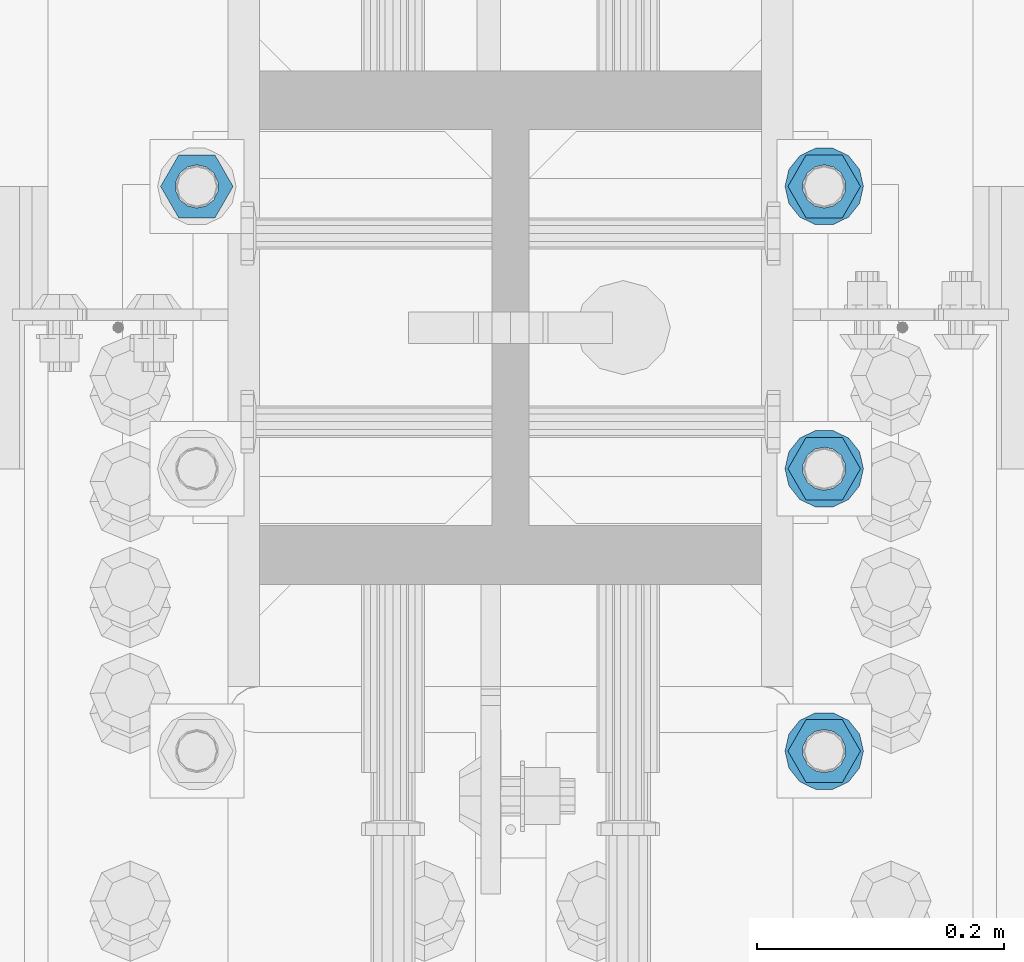
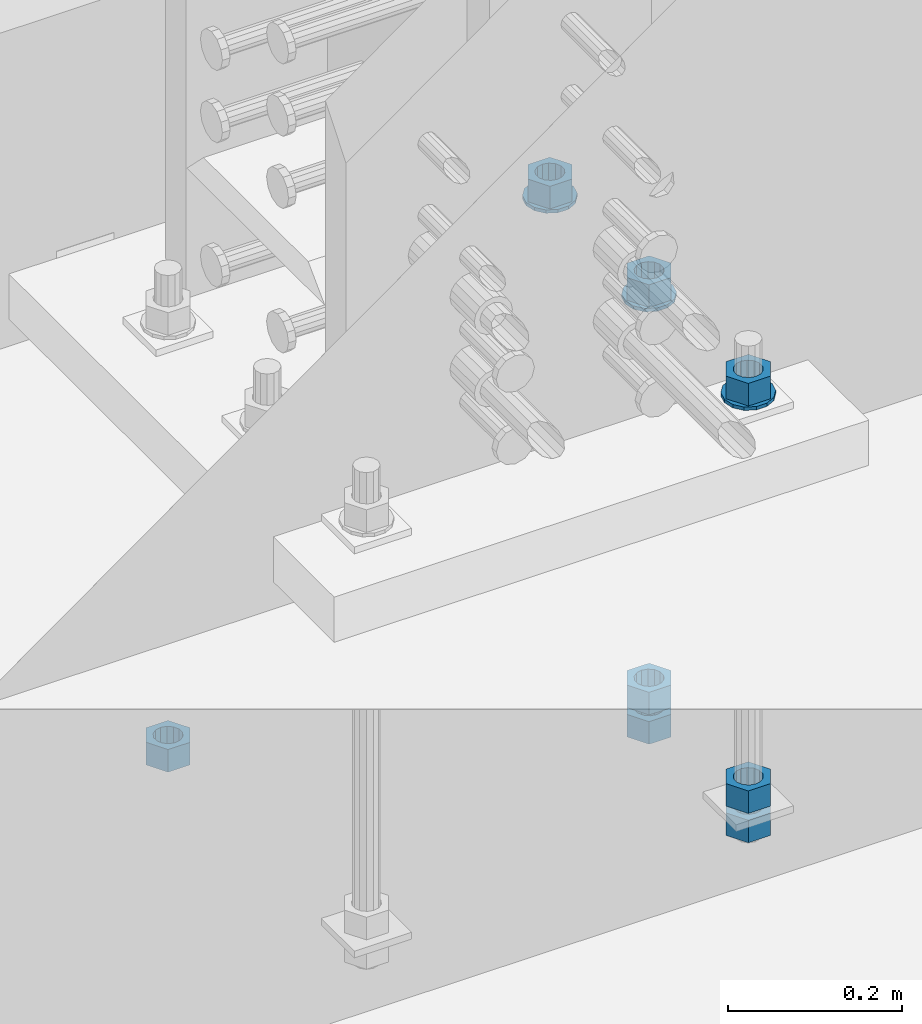
# One storey, part 1014 of 1763: 11 columns, 1 element without a shape of its own.
"""IFC2X3 building model written with IfcOpenShell, lengths in millimetres."""

import ifcopenshell
import ifcopenshell.guid

model = None  # the IFC model being written
_history = None  # IfcOwnerHistory: only IFC2X3 demands one
_inside = {}  # id of a spatial element -> (the spatial element, [elements in it])
_under = {}  # id of a project, library or spatial element -> (it, [spatial elements below it])
_declared = {}  # id of a project -> (the project, [libraries it declares])
_typed = {}  # id of a type object -> (the type object, [elements of that type])
_made_of = {}  # id of a material, layer set ... -> (it, [elements and type objects made of it])


def new_model(schema):
    """Start an empty IFC model of exactly this schema.

    Asked for "IFC4X3", IfcOpenShell would pick the latest addendum, in which some entities
    have other attributes; the version numbers below select the first issue.
    IFC2X3 requires an IfcOwnerHistory on every rooted entity: one is made here for all.
    """
    global model, _history
    if schema == "IFC4X3":
        model = ifcopenshell.file(schema_version=(4, 3, 0, 0))
    else:
        model = ifcopenshell.file(schema=schema)
    _inside.clear()
    _under.clear()
    _declared.clear()
    _typed.clear()
    _made_of.clear()
    _history = None
    if model.schema == "IFC2X3":
        org = make("IfcOrganization", Name="unknown")
        user = make(
            "IfcPersonAndOrganization",
            ThePerson=make("IfcPerson", FamilyName="unknown"),
            TheOrganization=org,
        )
        app = make(
            "IfcApplication",
            ApplicationDeveloper=org,
            Version="unknown",
            ApplicationFullName="unknown",
            ApplicationIdentifier="unknown",
        )
        _history = make(
            "IfcOwnerHistory",
            OwningUser=user,
            OwningApplication=app,
            ChangeAction="ADDED",
            CreationDate=0,
        )
    return model


def make(cls, **values):
    """One entity of the class cls with the attributes given. An attribute that is None is left unset."""
    return model.create_entity(
        cls, **{name: value for name, value in values.items() if value is not None}
    )


def rooted(cls, **values):
    """An entity with a GlobalId (a new one), such as an element, a storey or a relation."""
    return make(cls, GlobalId=ifcopenshell.guid.new(), OwnerHistory=_history, **values)


def si_unit(unit_type, name, prefix=None):
    """IfcSIUnit, for example si_unit("LENGTHUNIT", "METRE", prefix="MILLI")."""
    return make("IfcSIUnit", UnitType=unit_type, Prefix=prefix, Name=name)


def assignment(units):
    """IfcUnitAssignment: the units of a project."""
    return None if units is None else make("IfcUnitAssignment", Units=units)


def point(xyz):
    """IfcCartesianPoint."""
    return None if xyz is None else make("IfcCartesianPoint", Coordinates=xyz)


def direction(xyz):
    """IfcDirection."""
    return None if xyz is None else make("IfcDirection", DirectionRatios=xyz)


def frame(location, z_axis=None, x_axis=None):
    """IfcAxis2Placement3D, a coordinate frame: its origin and axes. An axis left out is left unset."""
    return make(
        "IfcAxis2Placement3D",
        Location=point(location),
        Axis=direction(z_axis),
        RefDirection=direction(x_axis),
    )


def origin_with_axes():
    """The frame at (0, 0, 0) with the z axis (0, 0, 1) and the x axis (1, 0, 0) written out."""
    return frame((0.0, 0.0, 0.0), z_axis=(0.0, 0.0, 1.0), x_axis=(1.0, 0.0, 0.0))


def place(relative_to, where):
    """IfcLocalPlacement: puts the frame where relative to a parent placement (None: the world)."""
    return make(
        "IfcLocalPlacement", PlacementRelTo=relative_to, RelativePlacement=where
    )


def context(
    kind, dimensions, precision=None, world=None, true_north=None, identifier=None
):
    """IfcGeometricRepresentationContext, for example the 3D "Model" context."""
    return make(
        "IfcGeometricRepresentationContext",
        ContextIdentifier=identifier,
        ContextType=kind,
        CoordinateSpaceDimension=dimensions,
        Precision=precision,
        WorldCoordinateSystem=world,
        TrueNorth=true_north,
    )


def subcontext(parent, identifier, kind, view, scale=None):
    """IfcGeometricRepresentationSubContext, for example "Body" below "Model"."""
    return make(
        "IfcGeometricRepresentationSubContext",
        ContextIdentifier=identifier,
        ContextType=kind,
        ParentContext=parent,
        TargetScale=scale,
        TargetView=view,
    )


def project(units=None, contexts=None):
    """IfcProject with its units and contexts."""
    return rooted(
        "IfcProject",
        Name="project",
        RepresentationContexts=contexts,
        UnitsInContext=assignment(units),
    )


def spatial(cls, under=None, at=None, **own):
    """A site, building, storey or space (cls), placed at a placement, below another one or the project."""
    s = rooted(cls, ObjectPlacement=at, **own)
    if under is not None:
        _under.setdefault(under.id(), (under, []))[1].append(s)
    return s


def faces_of(points, faces, orient=None, outer=None):
    """IfcFace entities. A face is a list of loops; a loop is a list of indices into points, from 0.

    orient and outer hold one flag for each loop. By default every Orientation is true, the
    first loop of a face is its IfcFaceOuterBound and the others are IfcFaceBound.
    """
    made = []
    for i, loops in enumerate(faces):
        bounds = []
        for j, loop in enumerate(loops):
            is_outer = j == 0 if outer is None else outer[i][j]
            bounds.append(
                make(
                    "IfcFaceOuterBound" if is_outer else "IfcFaceBound",
                    Bound=make("IfcPolyLoop", Polygon=[points[k] for k in loop]),
                    Orientation=True if orient is None else orient[i][j],
                )
            )
        made.append(make("IfcFace", Bounds=bounds))
    return made


def faceted_brep(points, faces, orient=None, outer=None, voids=None):
    """IfcFacetedBrep: a solid bounded by flat faces; with voids (closed shells), ...WithVoids."""
    shared = [point(p) for p in points]
    hull = make("IfcClosedShell", CfsFaces=faces_of(shared, faces, orient, outer))
    if voids is None:
        return make("IfcFacetedBrep", Outer=hull)
    return make(
        "IfcFacetedBrepWithVoids",
        Outer=hull,
        Voids=[
            make(cls, CfsFaces=faces_of(shared, fs, o, b)) for cls, fs, o, b in voids
        ],
    )


def shape(context_of_items, identifier, shape_type, items):
    """IfcShapeRepresentation: the items that make up one representation, for example the "Body"."""
    return make(
        "IfcShapeRepresentation",
        ContextOfItems=context_of_items,
        RepresentationIdentifier=identifier,
        RepresentationType=shape_type,
        Items=items,
    )


def material(Name=None, Category=None):
    """IfcMaterial."""
    return make("IfcMaterial", Name=Name, Category=Category)


def made_of(thing, what):
    """Note that an element or type object is made of a material, layer set ...; save() writes the relation."""
    if what is not None:
        _made_of.setdefault(what.id(), (what, []))[1].append(thing)
    return thing


def type_object(cls, material=None, **own):
    """A type object (cls), such as IfcWallType, which elements share."""
    return made_of(rooted(cls, **own), material)


def element(
    cls,
    number,
    at=None,
    inside=None,
    cuts=None,
    type_object=None,
    material=None,
    context=None,
    identifier="Body",
    shape_type=None,
    held_by="IfcProductDefinitionShape",
    body=None,
    shapes=None,
    **own,
):
    """One element of the class cls, such as IfcWall. Its Tag is "e" and its number.

    at: its placement. inside: the storey or other place that contains it. cuts: it is an
    opening in that element (IfcRelVoidsElement). A single representation is given by context,
    identifier, shape_type and body (its items); several are given by shapes. held_by: the class
    of the entity that holds the representations. save() writes the other relations.
    """
    e = rooted(cls, Tag="e%d" % number, ObjectPlacement=at, **own)
    if body is not None:
        shapes = [shape(context, identifier, shape_type, body)]
    if shapes is not None:
        e.Representation = make(held_by, Representations=shapes)
    if inside is not None:
        _inside.setdefault(inside.id(), (inside, []))[1].append(e)
    if cuts is not None:
        rooted(
            "IfcRelVoidsElement", RelatingBuildingElement=cuts, RelatedOpeningElement=e
        )
    if type_object is not None:
        _typed.setdefault(type_object.id(), (type_object, []))[1].append(e)
    return made_of(e, material)


def aggregate(whole, parts):
    """IfcRelAggregates: a whole, such as a stair, and the parts it consists of."""
    return rooted("IfcRelAggregates", RelatingObject=whole, RelatedObjects=parts)


def save(model, path):
    """Write the relations noted so far, then the file.

    IfcRelAggregates (storeys below a building ...), IfcRelContainedInSpatialStructure (elements
    in a storey), IfcRelDefinesByType, IfcRelAssociatesMaterial and IfcRelDeclares: one each for
    every whole, place, type object, material and project.
    """
    for whole, parts in _under.values():
        aggregate(whole, parts)
    for where, things in _inside.values():
        rooted(
            "IfcRelContainedInSpatialStructure",
            RelatedElements=things,
            RelatingStructure=where,
        )
    for kind, things in _typed.values():
        rooted("IfcRelDefinesByType", RelatedObjects=things, RelatingType=kind)
    for what, things in _made_of.values():
        rooted("IfcRelAssociatesMaterial", RelatedObjects=things, RelatingMaterial=what)
    for by, libraries in _declared.values():
        rooted("IfcRelDeclares", RelatingContext=by, RelatedDefinitions=libraries)
    model.write(path)


model = new_model("IFC2X3")

# Units and contexts
model_context = context("Model", 3, precision=1e-05, world=origin_with_axes())
body_context = subcontext(model_context, "Body", "Model", "MODEL_VIEW")
ifc_project = project(units=[si_unit("LENGTHUNIT", "METRE", prefix="MILLI"), si_unit("AREAUNIT", "SQUARE_METRE"), si_unit("VOLUMEUNIT", "CUBIC_METRE"), si_unit("MASSUNIT", "GRAM", prefix="KILO"), si_unit("TIMEUNIT", "SECOND"), si_unit("PLANEANGLEUNIT", "RADIAN"), si_unit("SOLIDANGLEUNIT", "STERADIAN"), si_unit("THERMODYNAMICTEMPERATUREUNIT", "DEGREE_CELSIUS"), si_unit("LUMINOUSINTENSITYUNIT", "LUMEN")], contexts=[model_context])

# Site, building, storey
site_placement = place(None, origin_with_axes())
site = spatial("IfcSite", under=ifc_project, at=site_placement, CompositionType="ELEMENT")
building_placement = place(site_placement, origin_with_axes())
building = spatial("IfcBuilding", under=site, at=building_placement, Name="Undefined", CompositionType="ELEMENT")
storey_placement = place(building_placement, origin_with_axes())
storey = spatial("IfcBuildingStorey", under=building, at=storey_placement, Name="Undefined", CompositionType="ELEMENT", Elevation=0.0)

# Assembly, columns
assembly_placement = place(storey_placement, origin_with_axes())
assembly = element("IfcElementAssembly", 1, at=assembly_placement, inside=storey, Name="TEMPLATE", AssemblyPlace="NOTDEFINED", PredefinedType="RIGID_FRAME")
ifc_material_1 = material(Name="STEEL/A563")
column_type_1 = type_object("IfcColumnType", Name="1-1/4_HEAVY_HEX_NUT", PredefinedType="NOTDEFINED")
column_1_placement = place(assembly_placement, frame((-23773.8372736984, 13347.6999999999, 3957.6375), z_axis=(0.0, 1.0, 0.0), x_axis=(0.0, 0.0, -1.0)))
column_1 = element("IfcColumn", 2, at=column_1_placement, type_object=column_type_1, material=ifc_material_1, Name="NUT", ObjectType="1-1/4_HEAVY_HEX_NUT", context=body_context, shape_type="Brep", body=[
    faceted_brep([(0.0, -29.3700008392334, 0.0), (0.0, -14.6800003051758, -25.4300003051758), (31.75, -14.6800003051758, -25.4300003051758), (31.75, -29.3700008392334, 0.0), (0.0, 14.6800003051758, -25.4300003051758), (31.75, 14.6800003051758, -25.4300003051758), (0.0, 29.3700008392334, 0.0), (31.75, 29.3700008392334, 0.0), (0.0, 14.6800003051758, 25.4300003051758), (31.75, 14.6800003051758, 25.4300003051758), (0.0, -14.6800003051758, 25.4300003051758), (31.75, -14.6800003051758, 25.4300003051758), (0.0, 0.0, 17.4599990844727), (0.0, 7.57560968776022, 15.730915608714), (31.75, 7.57560968775942, 15.7309156087145), (31.75, 0.0, 17.4599990844727), (0.0, 13.6507769681037, 10.8861313696252), (31.75, 13.6507769681048, 10.8861313696314), (0.0, 17.0222404541215, 3.88521530314756), (31.75, 17.02224045412, 3.88521530315316), (0.0, 17.0222404541215, -3.88521530314756), (31.75, 17.02224045412, -3.88521530315332), (0.0, 13.6507769681037, -10.8861313696252), (31.75, 13.6507769681048, -10.8861313696316), (0.0, 7.57560968776022, -15.730915608714), (31.75, 7.57560968775942, -15.7309156087146), (0.0, 0.0, -17.4599990844727), (31.75, 0.0, -17.4599990844727), (0.0, -7.57560968776022, -15.730915608714), (31.75, -7.57560968775942, -15.7309156087145), (0.0, -13.6507769681037, -10.8861313696252), (31.75, -13.6507769681048, -10.8861313696314), (0.0, -17.0222404541215, -3.88521530314756), (31.75, -17.02224045412, -3.88521530315316), (0.0, -17.0222404541215, 3.88521530314756), (31.75, -17.02224045412, 3.88521530315332), (0.0, -13.6507769681037, 10.8861313696252), (31.75, -13.6507769681048, 10.8861313696316), (0.0, -7.57560968776022, 15.730915608714), (31.75, -7.57560968775942, 15.7309156087146)], [[[0, 1, 2, 3]], [[1, 4, 5, 2]], [[4, 6, 7, 5]], [[6, 8, 9, 7]], [[8, 10, 11, 9]], [[10, 0, 3, 11]], [[12, 13, 14, 15]], [[13, 16, 17, 14]], [[16, 18, 19, 17]], [[18, 20, 21, 19]], [[20, 22, 23, 21]], [[22, 24, 25, 23]], [[24, 26, 27, 25]], [[26, 28, 29, 27]], [[28, 30, 31, 29]], [[30, 32, 33, 31]], [[32, 34, 35, 33]], [[34, 36, 37, 35]], [[36, 38, 39, 37]], [[38, 12, 15, 39]], [[5, 7, 9, 11, 3, 2], [17, 19, 21, 23, 25, 27, 29, 31, 33, 35, 37, 39, 15, 14]], [[10, 8, 6, 4, 1, 0], [38, 36, 34, 32, 30, 28, 26, 24, 22, 20, 18, 16, 13, 12]]]),
])
column_2_placement = place(assembly_placement, frame((-23773.8372736984, 13347.6999999999, 3384.55), z_axis=(0.0, 1.0, 0.0), x_axis=(0.0, 0.0, -1.0)))
column_2 = element("IfcColumn", 3, at=column_2_placement, type_object=column_type_1, material=ifc_material_1, Name="NUT", ObjectType="1-1/4_HEAVY_HEX_NUT", context=body_context, shape_type="Brep", body=[
    faceted_brep([(0.0, -29.3700008392334, 0.0), (0.0, -14.6800003051758, -25.4300003051758), (31.75, -14.6800003051758, -25.4300003051758), (31.75, -29.3700008392334, 0.0), (0.0, 14.6800003051758, -25.4300003051758), (31.75, 14.6800003051758, -25.4300003051758), (0.0, 29.3700008392334, 0.0), (31.75, 29.3700008392334, 0.0), (0.0, 14.6800003051758, 25.4300003051758), (31.75, 14.6800003051758, 25.4300003051758), (0.0, -14.6800003051758, 25.4300003051758), (31.75, -14.6800003051758, 25.4300003051758), (0.0, 0.0, 17.4599990844727), (0.0, 7.57560968776022, 15.730915608714), (31.75, 7.57560968775942, 15.7309156087145), (31.75, 0.0, 17.4599990844727), (0.0, 13.6507769681037, 10.8861313696252), (31.75, 13.6507769681048, 10.8861313696314), (0.0, 17.0222404541215, 3.88521530314756), (31.75, 17.02224045412, 3.88521530315316), (0.0, 17.0222404541215, -3.88521530314756), (31.75, 17.02224045412, -3.88521530315332), (0.0, 13.6507769681037, -10.8861313696252), (31.75, 13.6507769681048, -10.8861313696316), (0.0, 7.57560968776022, -15.730915608714), (31.75, 7.57560968775942, -15.7309156087146), (0.0, 0.0, -17.4599990844727), (31.75, 0.0, -17.4599990844727), (0.0, -7.57560968776022, -15.730915608714), (31.75, -7.57560968775942, -15.7309156087145), (0.0, -13.6507769681037, -10.8861313696252), (31.75, -13.6507769681048, -10.8861313696314), (0.0, -17.0222404541215, -3.88521530314756), (31.75, -17.02224045412, -3.88521530315316), (0.0, -17.0222404541215, 3.88521530314756), (31.75, -17.02224045412, 3.88521530315332), (0.0, -13.6507769681037, 10.8861313696252), (31.75, -13.6507769681048, 10.8861313696316), (0.0, -7.57560968776022, 15.730915608714), (31.75, -7.57560968775942, 15.7309156087146)], [[[0, 1, 2, 3]], [[1, 4, 5, 2]], [[4, 6, 7, 5]], [[6, 8, 9, 7]], [[8, 10, 11, 9]], [[10, 0, 3, 11]], [[12, 13, 14, 15]], [[13, 16, 17, 14]], [[16, 18, 19, 17]], [[18, 20, 21, 19]], [[20, 22, 23, 21]], [[22, 24, 25, 23]], [[24, 26, 27, 25]], [[26, 28, 29, 27]], [[28, 30, 31, 29]], [[30, 32, 33, 31]], [[32, 34, 35, 33]], [[34, 36, 37, 35]], [[36, 38, 39, 37]], [[38, 12, 15, 39]], [[5, 7, 9, 11, 3, 2], [17, 19, 21, 23, 25, 27, 29, 31, 33, 35, 37, 39, 15, 14]], [[10, 8, 6, 4, 1, 0], [38, 36, 34, 32, 30, 28, 26, 24, 22, 20, 18, 16, 13, 12]]]),
])
column_3_placement = place(assembly_placement, frame((-23773.8372736984, 13347.6999999999, 3343.275), z_axis=(0.0, 1.0, 0.0), x_axis=(0.0, 0.0, -1.0)))
column_3 = element("IfcColumn", 4, at=column_3_placement, type_object=column_type_1, material=ifc_material_1, Name="NUT", ObjectType="1-1/4_HEAVY_HEX_NUT", context=body_context, shape_type="Brep", body=[
    faceted_brep([(0.0, -29.3700008392334, 0.0), (0.0, -14.6800003051758, -25.4300003051758), (31.75, -14.6800003051758, -25.4300003051758), (31.75, -29.3700008392334, 0.0), (0.0, 14.6800003051758, -25.4300003051758), (31.75, 14.6800003051758, -25.4300003051758), (0.0, 29.3700008392334, 0.0), (31.75, 29.3700008392334, 0.0), (0.0, 14.6800003051758, 25.4300003051758), (31.75, 14.6800003051758, 25.4300003051758), (0.0, -14.6800003051758, 25.4300003051758), (31.75, -14.6800003051758, 25.4300003051758), (0.0, 0.0, 17.4599990844727), (0.0, 7.57560968776022, 15.730915608714), (31.75, 7.57560968775942, 15.7309156087145), (31.75, 0.0, 17.4599990844727), (0.0, 13.6507769681037, 10.8861313696252), (31.75, 13.6507769681048, 10.8861313696314), (0.0, 17.0222404541215, 3.88521530314756), (31.75, 17.02224045412, 3.88521530315316), (0.0, 17.0222404541215, -3.88521530314756), (31.75, 17.02224045412, -3.88521530315332), (0.0, 13.6507769681037, -10.8861313696252), (31.75, 13.6507769681048, -10.8861313696316), (0.0, 7.57560968776022, -15.730915608714), (31.75, 7.57560968775942, -15.7309156087146), (0.0, 0.0, -17.4599990844727), (31.75, 0.0, -17.4599990844727), (0.0, -7.57560968776022, -15.730915608714), (31.75, -7.57560968775942, -15.7309156087145), (0.0, -13.6507769681037, -10.8861313696252), (31.75, -13.6507769681048, -10.8861313696314), (0.0, -17.0222404541215, -3.88521530314756), (31.75, -17.02224045412, -3.88521530315316), (0.0, -17.0222404541215, 3.88521530314756), (31.75, -17.02224045412, 3.88521530315332), (0.0, -13.6507769681037, 10.8861313696252), (31.75, -13.6507769681048, 10.8861313696316), (0.0, -7.57560968776022, 15.730915608714), (31.75, -7.57560968775942, 15.7309156087146)], [[[0, 1, 2, 3]], [[1, 4, 5, 2]], [[4, 6, 7, 5]], [[6, 8, 9, 7]], [[8, 10, 11, 9]], [[10, 0, 3, 11]], [[12, 13, 14, 15]], [[13, 16, 17, 14]], [[16, 18, 19, 17]], [[18, 20, 21, 19]], [[20, 22, 23, 21]], [[22, 24, 25, 23]], [[24, 26, 27, 25]], [[26, 28, 29, 27]], [[28, 30, 31, 29]], [[30, 32, 33, 31]], [[32, 34, 35, 33]], [[34, 36, 37, 35]], [[36, 38, 39, 37]], [[38, 12, 15, 39]], [[5, 7, 9, 11, 3, 2], [17, 19, 21, 23, 25, 27, 29, 31, 33, 35, 37, 39, 15, 14]], [[10, 8, 6, 4, 1, 0], [38, 36, 34, 32, 30, 28, 26, 24, 22, 20, 18, 16, 13, 12]]]),
])
column_4_placement = place(assembly_placement, frame((-23773.8372736984, 13576.2999999999, 3957.6375), z_axis=(0.0, 1.0, 0.0), x_axis=(0.0, 0.0, -1.0)))
column_4 = element("IfcColumn", 5, at=column_4_placement, type_object=column_type_1, material=ifc_material_1, Name="NUT", ObjectType="1-1/4_HEAVY_HEX_NUT", context=body_context, shape_type="Brep", body=[
    faceted_brep([(0.0, -29.3700008392334, 0.0), (0.0, -14.6800003051758, -25.4300003051758), (31.75, -14.6800003051758, -25.4300003051758), (31.75, -29.3700008392334, 0.0), (0.0, 14.6800003051758, -25.4300003051758), (31.75, 14.6800003051758, -25.4300003051758), (0.0, 29.3700008392334, 0.0), (31.75, 29.3700008392334, 0.0), (0.0, 14.6800003051758, 25.4300003051758), (31.75, 14.6800003051758, 25.4300003051758), (0.0, -14.6800003051758, 25.4300003051758), (31.75, -14.6800003051758, 25.4300003051758), (0.0, 0.0, 17.4599990844727), (0.0, 7.57560968776022, 15.730915608714), (31.75, 7.57560968775942, 15.7309156087145), (31.75, 0.0, 17.4599990844727), (0.0, 13.6507769681037, 10.8861313696252), (31.75, 13.6507769681048, 10.8861313696314), (0.0, 17.0222404541215, 3.88521530314756), (31.75, 17.02224045412, 3.88521530315316), (0.0, 17.0222404541215, -3.88521530314756), (31.75, 17.02224045412, -3.88521530315332), (0.0, 13.6507769681037, -10.8861313696252), (31.75, 13.6507769681048, -10.8861313696316), (0.0, 7.57560968776022, -15.730915608714), (31.75, 7.57560968775942, -15.7309156087146), (0.0, 0.0, -17.4599990844727), (31.75, 0.0, -17.4599990844727), (0.0, -7.57560968776022, -15.730915608714), (31.75, -7.57560968775942, -15.7309156087145), (0.0, -13.6507769681037, -10.8861313696252), (31.75, -13.6507769681048, -10.8861313696314), (0.0, -17.0222404541215, -3.88521530314756), (31.75, -17.02224045412, -3.88521530315316), (0.0, -17.0222404541215, 3.88521530314756), (31.75, -17.02224045412, 3.88521530315332), (0.0, -13.6507769681037, 10.8861313696252), (31.75, -13.6507769681048, 10.8861313696316), (0.0, -7.57560968776022, 15.730915608714), (31.75, -7.57560968775942, 15.7309156087146)], [[[0, 1, 2, 3]], [[1, 4, 5, 2]], [[4, 6, 7, 5]], [[6, 8, 9, 7]], [[8, 10, 11, 9]], [[10, 0, 3, 11]], [[12, 13, 14, 15]], [[13, 16, 17, 14]], [[16, 18, 19, 17]], [[18, 20, 21, 19]], [[20, 22, 23, 21]], [[22, 24, 25, 23]], [[24, 26, 27, 25]], [[26, 28, 29, 27]], [[28, 30, 31, 29]], [[30, 32, 33, 31]], [[32, 34, 35, 33]], [[34, 36, 37, 35]], [[36, 38, 39, 37]], [[38, 12, 15, 39]], [[5, 7, 9, 11, 3, 2], [17, 19, 21, 23, 25, 27, 29, 31, 33, 35, 37, 39, 15, 14]], [[10, 8, 6, 4, 1, 0], [38, 36, 34, 32, 30, 28, 26, 24, 22, 20, 18, 16, 13, 12]]]),
])
column_5_placement = place(assembly_placement, frame((-23773.8372736984, 13576.2999999999, 3384.55), z_axis=(0.0, 1.0, 0.0), x_axis=(0.0, 0.0, -1.0)))
column_5 = element("IfcColumn", 6, at=column_5_placement, type_object=column_type_1, material=ifc_material_1, Name="NUT", ObjectType="1-1/4_HEAVY_HEX_NUT", context=body_context, shape_type="Brep", body=[
    faceted_brep([(0.0, -29.3700008392334, 0.0), (0.0, -14.6800003051758, -25.4300003051758), (31.75, -14.6800003051758, -25.4300003051758), (31.75, -29.3700008392334, 0.0), (0.0, 14.6800003051758, -25.4300003051758), (31.75, 14.6800003051758, -25.4300003051758), (0.0, 29.3700008392334, 0.0), (31.75, 29.3700008392334, 0.0), (0.0, 14.6800003051758, 25.4300003051758), (31.75, 14.6800003051758, 25.4300003051758), (0.0, -14.6800003051758, 25.4300003051758), (31.75, -14.6800003051758, 25.4300003051758), (0.0, 0.0, 17.4599990844727), (0.0, 7.57560968776022, 15.730915608714), (31.75, 7.57560968775942, 15.7309156087145), (31.75, 0.0, 17.4599990844727), (0.0, 13.6507769681037, 10.8861313696252), (31.75, 13.6507769681048, 10.8861313696314), (0.0, 17.0222404541215, 3.88521530314756), (31.75, 17.02224045412, 3.88521530315316), (0.0, 17.0222404541215, -3.88521530314756), (31.75, 17.02224045412, -3.88521530315332), (0.0, 13.6507769681037, -10.8861313696252), (31.75, 13.6507769681048, -10.8861313696316), (0.0, 7.57560968776022, -15.730915608714), (31.75, 7.57560968775942, -15.7309156087146), (0.0, 0.0, -17.4599990844727), (31.75, 0.0, -17.4599990844727), (0.0, -7.57560968776022, -15.730915608714), (31.75, -7.57560968775942, -15.7309156087145), (0.0, -13.6507769681037, -10.8861313696252), (31.75, -13.6507769681048, -10.8861313696314), (0.0, -17.0222404541215, -3.88521530314756), (31.75, -17.02224045412, -3.88521530315316), (0.0, -17.0222404541215, 3.88521530314756), (31.75, -17.02224045412, 3.88521530315332), (0.0, -13.6507769681037, 10.8861313696252), (31.75, -13.6507769681048, 10.8861313696316), (0.0, -7.57560968776022, 15.730915608714), (31.75, -7.57560968775942, 15.7309156087146)], [[[0, 1, 2, 3]], [[1, 4, 5, 2]], [[4, 6, 7, 5]], [[6, 8, 9, 7]], [[8, 10, 11, 9]], [[10, 0, 3, 11]], [[12, 13, 14, 15]], [[13, 16, 17, 14]], [[16, 18, 19, 17]], [[18, 20, 21, 19]], [[20, 22, 23, 21]], [[22, 24, 25, 23]], [[24, 26, 27, 25]], [[26, 28, 29, 27]], [[28, 30, 31, 29]], [[30, 32, 33, 31]], [[32, 34, 35, 33]], [[34, 36, 37, 35]], [[36, 38, 39, 37]], [[38, 12, 15, 39]], [[5, 7, 9, 11, 3, 2], [17, 19, 21, 23, 25, 27, 29, 31, 33, 35, 37, 39, 15, 14]], [[10, 8, 6, 4, 1, 0], [38, 36, 34, 32, 30, 28, 26, 24, 22, 20, 18, 16, 13, 12]]]),
])
column_6_placement = place(assembly_placement, frame((-23773.8372736984, 13576.2999999999, 3343.275), z_axis=(0.0, 1.0, 0.0), x_axis=(0.0, 0.0, -1.0)))
column_6 = element("IfcColumn", 7, at=column_6_placement, type_object=column_type_1, material=ifc_material_1, Name="NUT", ObjectType="1-1/4_HEAVY_HEX_NUT", context=body_context, shape_type="Brep", body=[
    faceted_brep([(0.0, -29.3700008392334, 0.0), (0.0, -14.6800003051758, -25.4300003051758), (31.75, -14.6800003051758, -25.4300003051758), (31.75, -29.3700008392334, 0.0), (0.0, 14.6800003051758, -25.4300003051758), (31.75, 14.6800003051758, -25.4300003051758), (0.0, 29.3700008392334, 0.0), (31.75, 29.3700008392334, 0.0), (0.0, 14.6800003051758, 25.4300003051758), (31.75, 14.6800003051758, 25.4300003051758), (0.0, -14.6800003051758, 25.4300003051758), (31.75, -14.6800003051758, 25.4300003051758), (0.0, 0.0, 17.4599990844727), (0.0, 7.57560968776022, 15.730915608714), (31.75, 7.57560968775942, 15.7309156087145), (31.75, 0.0, 17.4599990844727), (0.0, 13.6507769681037, 10.8861313696252), (31.75, 13.6507769681048, 10.8861313696314), (0.0, 17.0222404541215, 3.88521530314756), (31.75, 17.02224045412, 3.88521530315316), (0.0, 17.0222404541215, -3.88521530314756), (31.75, 17.02224045412, -3.88521530315332), (0.0, 13.6507769681037, -10.8861313696252), (31.75, 13.6507769681048, -10.8861313696316), (0.0, 7.57560968776022, -15.730915608714), (31.75, 7.57560968775942, -15.7309156087146), (0.0, 0.0, -17.4599990844727), (31.75, 0.0, -17.4599990844727), (0.0, -7.57560968776022, -15.730915608714), (31.75, -7.57560968775942, -15.7309156087145), (0.0, -13.6507769681037, -10.8861313696252), (31.75, -13.6507769681048, -10.8861313696314), (0.0, -17.0222404541215, -3.88521530314756), (31.75, -17.02224045412, -3.88521530315316), (0.0, -17.0222404541215, 3.88521530314756), (31.75, -17.02224045412, 3.88521530315332), (0.0, -13.6507769681037, 10.8861313696252), (31.75, -13.6507769681048, 10.8861313696316), (0.0, -7.57560968776022, 15.730915608714), (31.75, -7.57560968775942, 15.7309156087146)], [[[0, 1, 2, 3]], [[1, 4, 5, 2]], [[4, 6, 7, 5]], [[6, 8, 9, 7]], [[8, 10, 11, 9]], [[10, 0, 3, 11]], [[12, 13, 14, 15]], [[13, 16, 17, 14]], [[16, 18, 19, 17]], [[18, 20, 21, 19]], [[20, 22, 23, 21]], [[22, 24, 25, 23]], [[24, 26, 27, 25]], [[26, 28, 29, 27]], [[28, 30, 31, 29]], [[30, 32, 33, 31]], [[32, 34, 35, 33]], [[34, 36, 37, 35]], [[36, 38, 39, 37]], [[38, 12, 15, 39]], [[5, 7, 9, 11, 3, 2], [17, 19, 21, 23, 25, 27, 29, 31, 33, 35, 37, 39, 15, 14]], [[10, 8, 6, 4, 1, 0], [38, 36, 34, 32, 30, 28, 26, 24, 22, 20, 18, 16, 13, 12]]]),
])
column_7_placement = place(assembly_placement, frame((-24281.8372736984, 13804.8999999999, 3343.275), z_axis=(0.0, -1.0, 0.0), x_axis=(0.0, 0.0, -1.0)))
column_7 = element("IfcColumn", 8, at=column_7_placement, type_object=column_type_1, material=ifc_material_1, Name="NUT", ObjectType="1-1/4_HEAVY_HEX_NUT", context=body_context, shape_type="Brep", body=[
    faceted_brep([(0.0, -29.3700008392334, 0.0), (0.0, -14.6800003051758, -25.4300003051758), (31.75, -14.6800003051758, -25.4300003051758), (31.75, -29.3700008392334, 0.0), (0.0, 14.6800003051758, -25.4300003051758), (31.75, 14.6800003051758, -25.4300003051758), (0.0, 29.3700008392334, 0.0), (31.75, 29.3700008392334, 0.0), (0.0, 14.6800003051758, 25.4300003051758), (31.75, 14.6800003051758, 25.4300003051758), (0.0, -14.6800003051758, 25.4300003051758), (31.75, -14.6800003051758, 25.4300003051758), (0.0, 0.0, 17.4599990844727), (0.0, 7.57560968776022, 15.730915608714), (31.75, 7.57560968775942, 15.7309156087145), (31.75, 0.0, 17.4599990844727), (0.0, 13.6507769681037, 10.8861313696252), (31.75, 13.6507769681048, 10.8861313696314), (0.0, 17.0222404541215, 3.88521530314756), (31.75, 17.02224045412, 3.88521530315316), (0.0, 17.0222404541215, -3.88521530314756), (31.75, 17.02224045412, -3.88521530315332), (0.0, 13.6507769681037, -10.8861313696252), (31.75, 13.6507769681048, -10.8861313696316), (0.0, 7.57560968776022, -15.730915608714), (31.75, 7.57560968775942, -15.7309156087146), (0.0, 0.0, -17.4599990844727), (31.75, 0.0, -17.4599990844727), (0.0, -7.57560968776022, -15.730915608714), (31.75, -7.57560968775942, -15.7309156087145), (0.0, -13.6507769681037, -10.8861313696252), (31.75, -13.6507769681048, -10.8861313696314), (0.0, -17.0222404541215, -3.88521530314756), (31.75, -17.02224045412, -3.88521530315316), (0.0, -17.0222404541215, 3.88521530314756), (31.75, -17.02224045412, 3.88521530315332), (0.0, -13.6507769681037, 10.8861313696252), (31.75, -13.6507769681048, 10.8861313696316), (0.0, -7.57560968776022, 15.730915608714), (31.75, -7.57560968775942, 15.7309156087146)], [[[0, 1, 2, 3]], [[1, 4, 5, 2]], [[4, 6, 7, 5]], [[6, 8, 9, 7]], [[8, 10, 11, 9]], [[10, 0, 3, 11]], [[12, 13, 14, 15]], [[13, 16, 17, 14]], [[16, 18, 19, 17]], [[18, 20, 21, 19]], [[20, 22, 23, 21]], [[22, 24, 25, 23]], [[24, 26, 27, 25]], [[26, 28, 29, 27]], [[28, 30, 31, 29]], [[30, 32, 33, 31]], [[32, 34, 35, 33]], [[34, 36, 37, 35]], [[36, 38, 39, 37]], [[38, 12, 15, 39]], [[5, 7, 9, 11, 3, 2], [17, 19, 21, 23, 25, 27, 29, 31, 33, 35, 37, 39, 15, 14]], [[10, 8, 6, 4, 1, 0], [38, 36, 34, 32, 30, 28, 26, 24, 22, 20, 18, 16, 13, 12]]]),
])
column_8_placement = place(assembly_placement, frame((-23773.8372736984, 13804.8999999999, 3957.6375), z_axis=(0.0, 1.0, 0.0), x_axis=(0.0, 0.0, -1.0)))
column_8 = element("IfcColumn", 9, at=column_8_placement, type_object=column_type_1, material=ifc_material_1, Name="NUT", ObjectType="1-1/4_HEAVY_HEX_NUT", context=body_context, shape_type="Brep", body=[
    faceted_brep([(0.0, -29.3700008392334, 0.0), (0.0, -14.6800003051758, -25.4300003051758), (31.75, -14.6800003051758, -25.4300003051758), (31.75, -29.3700008392334, 0.0), (0.0, 14.6800003051758, -25.4300003051758), (31.75, 14.6800003051758, -25.4300003051758), (0.0, 29.3700008392334, 0.0), (31.75, 29.3700008392334, 0.0), (0.0, 14.6800003051758, 25.4300003051758), (31.75, 14.6800003051758, 25.4300003051758), (0.0, -14.6800003051758, 25.4300003051758), (31.75, -14.6800003051758, 25.4300003051758), (0.0, 0.0, 17.4599990844727), (0.0, 7.57560968776022, 15.730915608714), (31.75, 7.57560968775942, 15.7309156087145), (31.75, 0.0, 17.4599990844727), (0.0, 13.6507769681037, 10.8861313696252), (31.75, 13.6507769681048, 10.8861313696314), (0.0, 17.0222404541215, 3.88521530314756), (31.75, 17.02224045412, 3.88521530315316), (0.0, 17.0222404541215, -3.88521530314756), (31.75, 17.02224045412, -3.88521530315332), (0.0, 13.6507769681037, -10.8861313696252), (31.75, 13.6507769681048, -10.8861313696316), (0.0, 7.57560968776022, -15.730915608714), (31.75, 7.57560968775942, -15.7309156087146), (0.0, 0.0, -17.4599990844727), (31.75, 0.0, -17.4599990844727), (0.0, -7.57560968776022, -15.730915608714), (31.75, -7.57560968775942, -15.7309156087145), (0.0, -13.6507769681037, -10.8861313696252), (31.75, -13.6507769681048, -10.8861313696314), (0.0, -17.0222404541215, -3.88521530314756), (31.75, -17.02224045412, -3.88521530315316), (0.0, -17.0222404541215, 3.88521530314756), (31.75, -17.02224045412, 3.88521530315332), (0.0, -13.6507769681037, 10.8861313696252), (31.75, -13.6507769681048, 10.8861313696316), (0.0, -7.57560968776022, 15.730915608714), (31.75, -7.57560968775942, 15.7309156087146)], [[[0, 1, 2, 3]], [[1, 4, 5, 2]], [[4, 6, 7, 5]], [[6, 8, 9, 7]], [[8, 10, 11, 9]], [[10, 0, 3, 11]], [[12, 13, 14, 15]], [[13, 16, 17, 14]], [[16, 18, 19, 17]], [[18, 20, 21, 19]], [[20, 22, 23, 21]], [[22, 24, 25, 23]], [[24, 26, 27, 25]], [[26, 28, 29, 27]], [[28, 30, 31, 29]], [[30, 32, 33, 31]], [[32, 34, 35, 33]], [[34, 36, 37, 35]], [[36, 38, 39, 37]], [[38, 12, 15, 39]], [[5, 7, 9, 11, 3, 2], [17, 19, 21, 23, 25, 27, 29, 31, 33, 35, 37, 39, 15, 14]], [[10, 8, 6, 4, 1, 0], [38, 36, 34, 32, 30, 28, 26, 24, 22, 20, 18, 16, 13, 12]]]),
])
ifc_material_2 = material(Name="STEEL/F436")
column_type_2 = type_object("IfcColumnType", Name="1-1/4_WASHER", PredefinedType="NOTDEFINED")
column_9_placement = place(assembly_placement, frame((-23773.8372736984, 13347.6999999999, 3925.8875), z_axis=(0.0, 1.0, 0.0), x_axis=(0.0, 0.0, -1.0)))
column_9 = element("IfcColumn", 10, at=column_9_placement, type_object=column_type_2, material=ifc_material_2, Name="WASHER", ObjectType="1-1/4_WASHER", context=body_context, shape_type="Brep", body=[
    faceted_brep([(-4.54747350886464e-13, -31.7499999999964, 0.0), (0.0, -28.6057615559002, -13.7758087169827), (4.76249999999982, -28.6057615559002, -13.7758087169827), (4.76249999999982, -31.75, 0.0), (0.0, -19.795801209013, -24.8231495683602), (4.76249999999982, -19.795801209013, -24.8231495683602), (0.0, -7.06503965311276, -30.9539612117732), (4.76249999999982, -7.06503965311276, -30.9539612117732), (0.0, 7.06503965311276, -30.9539612117732), (4.76249999999982, 7.06503965311276, -30.9539612117732), (0.0, 19.7958012090166, -24.8231495683602), (4.76249999999982, 19.7958012090166, -24.8231495683602), (0.0, 28.6057615559039, -13.7758087169827), (4.76249999999982, 28.6057615559039, -13.7758087169827), (-5.91171556152403e-12, 31.7499999999891, 0.0), (4.76249999999982, 31.75, 0.0), (0.0, 28.6057615559002, 13.7758087169827), (4.76249999999982, 28.6057615559002, 13.7758087169827), (0.0, 19.795801209013, 24.8231495683602), (4.76249999999982, 19.795801209013, 24.8231495683602), (0.0, 7.06503965311276, 30.9539612117731), (4.76249999999982, 7.06503965311276, 30.9539612117731), (0.0, -7.06503965311276, 30.9539612117731), (4.76249999999982, -7.06503965311276, 30.9539612117731), (0.0, -19.7958012090166, 24.8231495683602), (4.76249999999982, -19.7958012090166, 24.8231495683602), (0.0, -28.6057615559039, 13.7758087169827), (4.76249999999982, -28.6057615559039, 13.7758087169827), (0.0, 0.0, 17.4599990844727), (0.0, 7.57560968776022, 15.730915608714), (4.76249999999982, 7.57560968775942, 15.7309156087145), (4.76249999999982, 0.0, 17.4599990844727), (0.0, 13.6507769681037, 10.8861313696252), (4.76249999999982, 13.6507769681048, 10.8861313696314), (0.0, 17.0222404541215, 3.88521530314756), (4.76249999999982, 17.02224045412, 3.88521530315316), (0.0, 17.0222404541215, -3.88521530314756), (4.76249999999982, 17.02224045412, -3.88521530315332), (0.0, 13.6507769681037, -10.8861313696252), (4.76249999999982, 13.6507769681048, -10.8861313696316), (0.0, 7.57560968776022, -15.730915608714), (4.76249999999982, 7.57560968775942, -15.7309156087146), (0.0, 0.0, -17.4599990844727), (4.76249999999982, 0.0, -17.4599990844727), (0.0, -7.57560968776022, -15.730915608714), (4.76249999999982, -7.57560968775942, -15.7309156087145), (0.0, -13.6507769681037, -10.8861313696252), (4.76249999999982, -13.6507769681048, -10.8861313696314), (0.0, -17.0222404541215, -3.88521530314756), (4.76249999999982, -17.02224045412, -3.88521530315316), (0.0, -17.0222404541215, 3.88521530314756), (4.76249999999982, -17.02224045412, 3.88521530315332), (0.0, -13.6507769681037, 10.8861313696252), (4.76249999999982, -13.6507769681048, 10.8861313696316), (0.0, -7.57560968776022, 15.730915608714), (4.76249999999982, -7.57560968775942, 15.7309156087146)], [[[0, 1, 2, 3]], [[1, 4, 5, 2]], [[4, 6, 7, 5]], [[6, 8, 9, 7]], [[8, 10, 11, 9]], [[10, 12, 13, 11]], [[12, 14, 15, 13]], [[14, 16, 17, 15]], [[16, 18, 19, 17]], [[18, 20, 21, 19]], [[20, 22, 23, 21]], [[22, 24, 25, 23]], [[24, 26, 27, 25]], [[26, 0, 3, 27]], [[28, 29, 30, 31]], [[29, 32, 33, 30]], [[32, 34, 35, 33]], [[34, 36, 37, 35]], [[36, 38, 39, 37]], [[38, 40, 41, 39]], [[40, 42, 43, 41]], [[42, 44, 45, 43]], [[44, 46, 47, 45]], [[46, 48, 49, 47]], [[48, 50, 51, 49]], [[50, 52, 53, 51]], [[52, 54, 55, 53]], [[54, 28, 31, 55]], [[5, 7, 9, 11, 13, 15, 17, 19, 21, 23, 25, 27, 3, 2], [33, 35, 37, 39, 41, 43, 45, 47, 49, 51, 53, 55, 31, 30]], [[26, 24, 22, 20, 18, 16, 14, 12, 10, 8, 6, 4, 1, 0], [54, 52, 50, 48, 46, 44, 42, 40, 38, 36, 34, 32, 29, 28]]]),
])
column_10_placement = place(assembly_placement, frame((-23773.8372736984, 13576.2999999999, 3925.8875), z_axis=(0.0, 1.0, 0.0), x_axis=(0.0, 0.0, -1.0)))
column_10 = element("IfcColumn", 11, at=column_10_placement, type_object=column_type_2, material=ifc_material_2, Name="WASHER", ObjectType="1-1/4_WASHER", context=body_context, shape_type="Brep", body=[
    faceted_brep([(-4.54747350886464e-13, -31.7499999999964, 0.0), (0.0, -28.6057615559002, -13.7758087169827), (4.76249999999982, -28.6057615559002, -13.7758087169827), (4.76249999999982, -31.75, 0.0), (0.0, -19.795801209013, -24.8231495683602), (4.76249999999982, -19.795801209013, -24.8231495683602), (0.0, -7.06503965311276, -30.9539612117732), (4.76249999999982, -7.06503965311276, -30.9539612117732), (0.0, 7.06503965311276, -30.9539612117732), (4.76249999999982, 7.06503965311276, -30.9539612117732), (0.0, 19.7958012090166, -24.8231495683602), (4.76249999999982, 19.7958012090166, -24.8231495683602), (0.0, 28.6057615559039, -13.7758087169827), (4.76249999999982, 28.6057615559039, -13.7758087169827), (-5.91171556152403e-12, 31.7499999999891, 0.0), (4.76249999999982, 31.75, 0.0), (0.0, 28.6057615559002, 13.7758087169827), (4.76249999999982, 28.6057615559002, 13.7758087169827), (0.0, 19.795801209013, 24.8231495683602), (4.76249999999982, 19.795801209013, 24.8231495683602), (0.0, 7.06503965311276, 30.9539612117731), (4.76249999999982, 7.06503965311276, 30.9539612117731), (0.0, -7.06503965311276, 30.9539612117731), (4.76249999999982, -7.06503965311276, 30.9539612117731), (0.0, -19.7958012090166, 24.8231495683602), (4.76249999999982, -19.7958012090166, 24.8231495683602), (0.0, -28.6057615559039, 13.7758087169827), (4.76249999999982, -28.6057615559039, 13.7758087169827), (0.0, 0.0, 17.4599990844727), (0.0, 7.57560968776022, 15.730915608714), (4.76249999999982, 7.57560968775942, 15.7309156087145), (4.76249999999982, 0.0, 17.4599990844727), (0.0, 13.6507769681037, 10.8861313696252), (4.76249999999982, 13.6507769681048, 10.8861313696314), (0.0, 17.0222404541215, 3.88521530314756), (4.76249999999982, 17.02224045412, 3.88521530315316), (0.0, 17.0222404541215, -3.88521530314756), (4.76249999999982, 17.02224045412, -3.88521530315332), (0.0, 13.6507769681037, -10.8861313696252), (4.76249999999982, 13.6507769681048, -10.8861313696316), (0.0, 7.57560968776022, -15.730915608714), (4.76249999999982, 7.57560968775942, -15.7309156087146), (0.0, 0.0, -17.4599990844727), (4.76249999999982, 0.0, -17.4599990844727), (0.0, -7.57560968776022, -15.730915608714), (4.76249999999982, -7.57560968775942, -15.7309156087145), (0.0, -13.6507769681037, -10.8861313696252), (4.76249999999982, -13.6507769681048, -10.8861313696314), (0.0, -17.0222404541215, -3.88521530314756), (4.76249999999982, -17.02224045412, -3.88521530315316), (0.0, -17.0222404541215, 3.88521530314756), (4.76249999999982, -17.02224045412, 3.88521530315332), (0.0, -13.6507769681037, 10.8861313696252), (4.76249999999982, -13.6507769681048, 10.8861313696316), (0.0, -7.57560968776022, 15.730915608714), (4.76249999999982, -7.57560968775942, 15.7309156087146)], [[[0, 1, 2, 3]], [[1, 4, 5, 2]], [[4, 6, 7, 5]], [[6, 8, 9, 7]], [[8, 10, 11, 9]], [[10, 12, 13, 11]], [[12, 14, 15, 13]], [[14, 16, 17, 15]], [[16, 18, 19, 17]], [[18, 20, 21, 19]], [[20, 22, 23, 21]], [[22, 24, 25, 23]], [[24, 26, 27, 25]], [[26, 0, 3, 27]], [[28, 29, 30, 31]], [[29, 32, 33, 30]], [[32, 34, 35, 33]], [[34, 36, 37, 35]], [[36, 38, 39, 37]], [[38, 40, 41, 39]], [[40, 42, 43, 41]], [[42, 44, 45, 43]], [[44, 46, 47, 45]], [[46, 48, 49, 47]], [[48, 50, 51, 49]], [[50, 52, 53, 51]], [[52, 54, 55, 53]], [[54, 28, 31, 55]], [[5, 7, 9, 11, 13, 15, 17, 19, 21, 23, 25, 27, 3, 2], [33, 35, 37, 39, 41, 43, 45, 47, 49, 51, 53, 55, 31, 30]], [[26, 24, 22, 20, 18, 16, 14, 12, 10, 8, 6, 4, 1, 0], [54, 52, 50, 48, 46, 44, 42, 40, 38, 36, 34, 32, 29, 28]]]),
])
column_11_placement = place(assembly_placement, frame((-23773.8372736984, 13804.8999999999, 3925.8875), z_axis=(0.0, 1.0, 0.0), x_axis=(0.0, 0.0, -1.0)))
column_11 = element("IfcColumn", 12, at=column_11_placement, type_object=column_type_2, material=ifc_material_2, Name="WASHER", ObjectType="1-1/4_WASHER", context=body_context, shape_type="Brep", body=[
    faceted_brep([(-4.54747350886464e-13, -31.7499999999964, 0.0), (0.0, -28.6057615559002, -13.7758087169827), (4.76249999999982, -28.6057615559002, -13.7758087169827), (4.76249999999982, -31.75, 0.0), (0.0, -19.795801209013, -24.8231495683602), (4.76249999999982, -19.795801209013, -24.8231495683602), (0.0, -7.06503965311276, -30.9539612117732), (4.76249999999982, -7.06503965311276, -30.9539612117732), (0.0, 7.06503965311276, -30.9539612117732), (4.76249999999982, 7.06503965311276, -30.9539612117732), (0.0, 19.7958012090166, -24.8231495683602), (4.76249999999982, 19.7958012090166, -24.8231495683602), (0.0, 28.6057615559039, -13.7758087169827), (4.76249999999982, 28.6057615559039, -13.7758087169827), (-5.91171556152403e-12, 31.7499999999891, 0.0), (4.76249999999982, 31.75, 0.0), (0.0, 28.6057615559002, 13.7758087169827), (4.76249999999982, 28.6057615559002, 13.7758087169827), (0.0, 19.795801209013, 24.8231495683602), (4.76249999999982, 19.795801209013, 24.8231495683602), (0.0, 7.06503965311276, 30.9539612117731), (4.76249999999982, 7.06503965311276, 30.9539612117731), (0.0, -7.06503965311276, 30.9539612117731), (4.76249999999982, -7.06503965311276, 30.9539612117731), (0.0, -19.7958012090166, 24.8231495683602), (4.76249999999982, -19.7958012090166, 24.8231495683602), (0.0, -28.6057615559039, 13.7758087169827), (4.76249999999982, -28.6057615559039, 13.7758087169827), (0.0, 0.0, 17.4599990844727), (0.0, 7.57560968776022, 15.730915608714), (4.76249999999982, 7.57560968775942, 15.7309156087145), (4.76249999999982, 0.0, 17.4599990844727), (0.0, 13.6507769681037, 10.8861313696252), (4.76249999999982, 13.6507769681048, 10.8861313696314), (0.0, 17.0222404541215, 3.88521530314756), (4.76249999999982, 17.02224045412, 3.88521530315316), (0.0, 17.0222404541215, -3.88521530314756), (4.76249999999982, 17.02224045412, -3.88521530315332), (0.0, 13.6507769681037, -10.8861313696252), (4.76249999999982, 13.6507769681048, -10.8861313696316), (0.0, 7.57560968776022, -15.730915608714), (4.76249999999982, 7.57560968775942, -15.7309156087146), (0.0, 0.0, -17.4599990844727), (4.76249999999982, 0.0, -17.4599990844727), (0.0, -7.57560968776022, -15.730915608714), (4.76249999999982, -7.57560968775942, -15.7309156087145), (0.0, -13.6507769681037, -10.8861313696252), (4.76249999999982, -13.6507769681048, -10.8861313696314), (0.0, -17.0222404541215, -3.88521530314756), (4.76249999999982, -17.02224045412, -3.88521530315316), (0.0, -17.0222404541215, 3.88521530314756), (4.76249999999982, -17.02224045412, 3.88521530315332), (0.0, -13.6507769681037, 10.8861313696252), (4.76249999999982, -13.6507769681048, 10.8861313696316), (0.0, -7.57560968776022, 15.730915608714), (4.76249999999982, -7.57560968775942, 15.7309156087146)], [[[0, 1, 2, 3]], [[1, 4, 5, 2]], [[4, 6, 7, 5]], [[6, 8, 9, 7]], [[8, 10, 11, 9]], [[10, 12, 13, 11]], [[12, 14, 15, 13]], [[14, 16, 17, 15]], [[16, 18, 19, 17]], [[18, 20, 21, 19]], [[20, 22, 23, 21]], [[22, 24, 25, 23]], [[24, 26, 27, 25]], [[26, 0, 3, 27]], [[28, 29, 30, 31]], [[29, 32, 33, 30]], [[32, 34, 35, 33]], [[34, 36, 37, 35]], [[36, 38, 39, 37]], [[38, 40, 41, 39]], [[40, 42, 43, 41]], [[42, 44, 45, 43]], [[44, 46, 47, 45]], [[46, 48, 49, 47]], [[48, 50, 51, 49]], [[50, 52, 53, 51]], [[52, 54, 55, 53]], [[54, 28, 31, 55]], [[5, 7, 9, 11, 13, 15, 17, 19, 21, 23, 25, 27, 3, 2], [33, 35, 37, 39, 41, 43, 45, 47, 49, 51, 53, 55, 31, 30]], [[26, 24, 22, 20, 18, 16, 14, 12, 10, 8, 6, 4, 1, 0], [54, 52, 50, 48, 46, 44, 42, 40, 38, 36, 34, 32, 29, 28]]]),
])
aggregate(assembly, [column_1, column_9, column_2, column_3, column_4, column_10, column_5, column_6, column_7, column_8, column_11])

save(model, "model.ifc")
